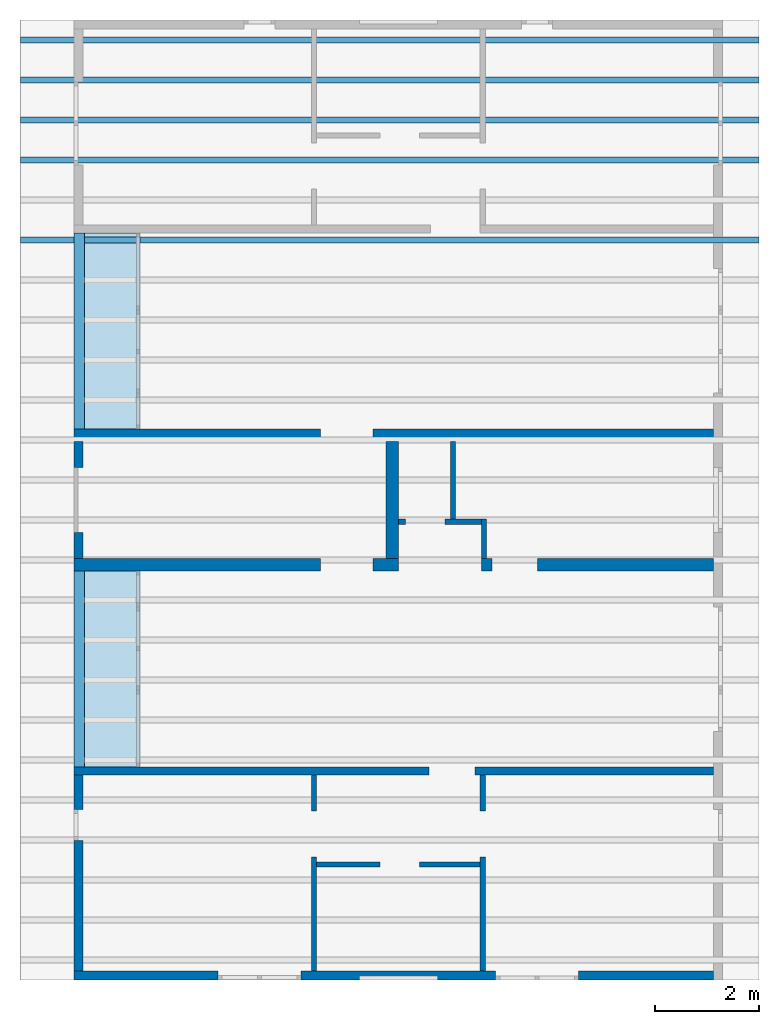
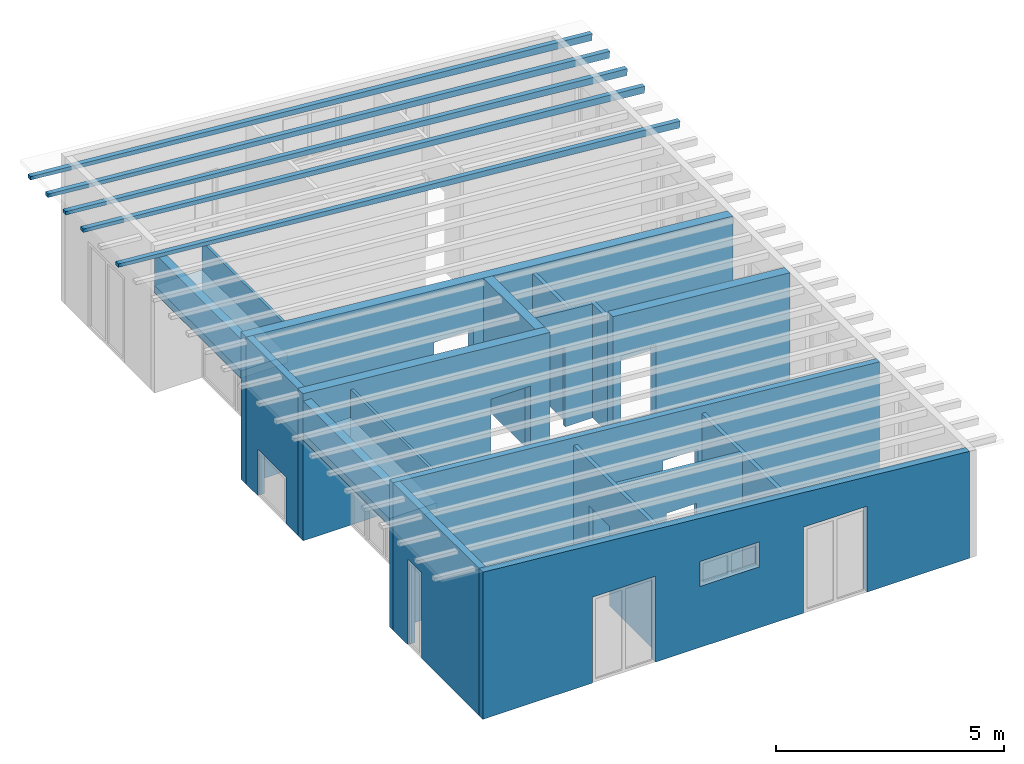
# One storey, part 1 of 13: 18 walls, 5 beams, 2 slabs, 19 openings.
"""IFC2X3 building model written with IfcOpenShell, lengths in millimetres."""

from ifc_helpers import new_model, entity, si_unit, converted_unit, frame, frame_2d, origin, origin_with_axes, place, context, project, spatial, rectangle, extrude, clip, halfspace, faceted_brep, material, layer, layer_set, layer_usage, element, save


model = new_model("IFC2X3")

# Units and contexts
model_context = context("Model", 3, precision=1e-05, world=origin())
plan_context = context("Plan", 3, precision=1e-05, world=origin())
ifc_project = project(units=[si_unit("LENGTHUNIT", "METRE", prefix="MILLI"), converted_unit("PLANEANGLEUNIT", "DEGREE", entity("IfcPlaneAngleMeasure", 0.0174532925199433), si_unit("PLANEANGLEUNIT", "RADIAN"), dimensions=[0, 0, 0, 0, 0, 0, 0]), si_unit("AREAUNIT", "SQUARE_METRE"), si_unit("VOLUMEUNIT", "CUBIC_METRE")], contexts=[model_context, plan_context])

# Building, storey
building_placement = place(None, origin())
building = spatial("IfcBuilding", under=ifc_project, at=building_placement, CompositionType="ELEMENT")
storey_placement = place(building_placement, frame((0.0, 0.0, 4770.0), z_axis=(0.0, 0.0, 1.0), x_axis=(1.0, 0.0, 0.0)))
storey = spatial("IfcBuildingStorey", under=building, at=storey_placement, Name="Geschoss", CompositionType="ELEMENT", Elevation=4770.0)

# Beams
beam_1_placement = place(storey_placement, frame((0.0, 0.0, -4770.0)))
element("IfcBeam", 1, at=beam_1_placement, inside=storey, context=model_context, shape_type="Brep", body=[
    faceted_brep([(34385.6880708781, 9363.02083332992, 7555.99098007664), (20155.7175901036, 9363.0208333996, 8710.60829407405), (20155.7175901036, 9483.0208333996, 8710.60829407405), (34385.6880708781, 9483.02083332992, 7555.99098007664), (34370.0000371835, 9363.02083333, 7376.67593442012), (34370.0000371835, 9483.02083333, 7376.67593442012), (20155.7175901036, 9483.0208333996, 8620.26450869515), (20155.7175901036, 9363.0208333996, 8620.26450869515), (34370.0000371835, 9363.02083333, 7376.67593442012), (20155.7175901036, 9363.0208333996, 8620.26450869515), (20155.7175901036, 9363.0208333996, 8710.60829407405), (34385.6880708781, 9363.02083332992, 7555.99098007664), (20155.7175901036, 9363.0208333996, 8620.26450869515), (20155.7175901036, 9483.0208333996, 8620.26450869515), (20155.7175901036, 9483.0208333996, 8710.60829407405), (20155.7175901036, 9363.0208333996, 8710.60829407405), (20155.7175901036, 9483.0208333996, 8620.26450869515), (34370.0000371835, 9483.02083333, 7376.67593442012), (34385.6880708781, 9483.02083332992, 7555.99098007664), (20155.7175901036, 9483.0208333996, 8710.60829407405), (34370.0000371835, 9483.02083333, 7376.67593442012), (34370.0000371835, 9363.02083333, 7376.67593442012), (34385.6880708781, 9363.02083332992, 7555.99098007664), (34385.6880708781, 9483.02083332992, 7555.99098007664)], [[[0, 1, 2, 3]], [[4, 5, 6, 7]], [[8, 9, 10, 11]], [[12, 13, 14, 15]], [[16, 17, 18, 19]], [[20, 21, 22, 23]]], orient=[[False], [False], [False], [False], [False], [False]]),
])
beam_2_placement = place(storey_placement, frame((0.0, 0.0, -4770.0)))
element("IfcBeam", 2, at=beam_2_placement, inside=storey, context=model_context, shape_type="Brep", body=[
    faceted_brep([(34385.6880708781, 8592.18749999659, 7555.99098007664), (20155.7175901036, 8592.18750006627, 8710.60829407405), (20155.7175901036, 8712.18750006627, 8710.60829407405), (34385.6880708781, 8712.18749999659, 7555.99098007664), (34370.0000371835, 8592.18749999666, 7376.67593442012), (34370.0000371835, 8712.18749999666, 7376.67593442012), (20155.7175901036, 8712.18750006627, 8620.26450869515), (20155.7175901036, 8592.18750006627, 8620.26450869515), (34370.0000371835, 8592.18749999666, 7376.67593442012), (20155.7175901036, 8592.18750006627, 8620.26450869515), (20155.7175901036, 8592.18750006627, 8710.60829407405), (34385.6880708781, 8592.18749999659, 7555.99098007664), (20155.7175901036, 8592.18750006627, 8620.26450869515), (20155.7175901036, 8712.18750006627, 8620.26450869515), (20155.7175901036, 8712.18750006627, 8710.60829407405), (20155.7175901036, 8592.18750006627, 8710.60829407405), (20155.7175901036, 8712.18750006627, 8620.26450869515), (34370.0000371835, 8712.18749999666, 7376.67593442012), (34385.6880708781, 8712.18749999659, 7555.99098007664), (20155.7175901036, 8712.18750006627, 8710.60829407405), (34370.0000371835, 8712.18749999666, 7376.67593442012), (34370.0000371835, 8592.18749999666, 7376.67593442012), (34385.6880708781, 8592.18749999659, 7555.99098007664), (34385.6880708781, 8712.18749999659, 7555.99098007664)], [[[0, 1, 2, 3]], [[4, 5, 6, 7]], [[8, 9, 10, 11]], [[12, 13, 14, 15]], [[16, 17, 18, 19]], [[20, 21, 22, 23]]], orient=[[False], [False], [False], [False], [False], [False]]),
])
beam_3_placement = place(storey_placement, frame((0.0, 0.0, -4770.0)))
element("IfcBeam", 3, at=beam_3_placement, inside=storey, context=model_context, shape_type="Brep", body=[
    faceted_brep([(34385.6880708781, 7821.35416666325, 7555.99098007664), (20155.7175901036, 7821.35416673293, 8710.60829407405), (20155.7175901036, 7941.35416673293, 8710.60829407405), (34385.6880708781, 7941.35416666325, 7555.99098007664), (34370.0000371835, 7821.35416666333, 7376.67593442012), (34370.0000371835, 7941.35416666333, 7376.67593442012), (20155.7175901036, 7941.35416673293, 8620.26450869515), (20155.7175901036, 7821.35416673293, 8620.26450869515), (34370.0000371835, 7821.35416666333, 7376.67593442012), (20155.7175901036, 7821.35416673293, 8620.26450869515), (20155.7175901036, 7821.35416673293, 8710.60829407405), (34385.6880708781, 7821.35416666325, 7555.99098007664), (20155.7175901036, 7821.35416673293, 8620.26450869515), (20155.7175901036, 7941.35416673293, 8620.26450869515), (20155.7175901036, 7941.35416673293, 8710.60829407405), (20155.7175901036, 7821.35416673293, 8710.60829407405), (20155.7175901036, 7941.35416673293, 8620.26450869515), (34370.0000371835, 7941.35416666333, 7376.67593442012), (34385.6880708781, 7941.35416666325, 7555.99098007664), (20155.7175901036, 7941.35416673293, 8710.60829407405), (34370.0000371835, 7941.35416666333, 7376.67593442012), (34370.0000371835, 7821.35416666333, 7376.67593442012), (34385.6880708781, 7821.35416666325, 7555.99098007664), (34385.6880708781, 7941.35416666325, 7555.99098007664)], [[[0, 1, 2, 3]], [[4, 5, 6, 7]], [[8, 9, 10, 11]], [[12, 13, 14, 15]], [[16, 17, 18, 19]], [[20, 21, 22, 23]]], orient=[[False], [False], [False], [False], [False], [False]]),
])
beam_4_placement = place(storey_placement, frame((0.0, 0.0, -4770.0)))
element("IfcBeam", 4, at=beam_4_placement, inside=storey, context=model_context, shape_type="Brep", body=[
    faceted_brep([(34385.6880708781, 7050.52083332992, 7555.99098007664), (20155.7175901036, 7050.5208333996, 8710.60829407405), (20155.7175901036, 7170.5208333996, 8710.60829407405), (34385.6880708781, 7170.52083332992, 7555.99098007664), (34370.0000371835, 7050.52083333, 7376.67593442012), (34370.0000371835, 7170.52083333, 7376.67593442012), (20155.7175901036, 7170.5208333996, 8620.26450869515), (20155.7175901036, 7050.5208333996, 8620.26450869515), (34370.0000371835, 7050.52083333, 7376.67593442012), (20155.7175901036, 7050.5208333996, 8620.26450869515), (20155.7175901036, 7050.5208333996, 8710.60829407405), (34385.6880708781, 7050.52083332992, 7555.99098007664), (20155.7175901036, 7050.5208333996, 8620.26450869515), (20155.7175901036, 7170.5208333996, 8620.26450869515), (20155.7175901036, 7170.5208333996, 8710.60829407405), (20155.7175901036, 7050.5208333996, 8710.60829407405), (20155.7175901036, 7170.5208333996, 8620.26450869515), (34370.0000371835, 7170.52083333, 7376.67593442012), (34385.6880708781, 7170.52083332992, 7555.99098007664), (20155.7175901036, 7170.5208333996, 8710.60829407405), (34370.0000371835, 7170.52083333, 7376.67593442012), (34370.0000371835, 7050.52083333, 7376.67593442012), (34385.6880708781, 7050.52083332992, 7555.99098007664), (34385.6880708781, 7170.52083332992, 7555.99098007664)], [[[0, 1, 2, 3]], [[4, 5, 6, 7]], [[8, 9, 10, 11]], [[12, 13, 14, 15]], [[16, 17, 18, 19]], [[20, 21, 22, 23]]], orient=[[False], [False], [False], [False], [False], [False]]),
])
beam_5_placement = place(storey_placement, frame((0.0, 0.0, -4770.0)))
element("IfcBeam", 5, at=beam_5_placement, inside=storey, context=model_context, shape_type="Brep", body=[
    faceted_brep([(34385.6880708781, 5508.85416666325, 7555.99098007664), (20155.7175901036, 5508.85416673293, 8710.60829407405), (20155.7175901036, 5628.85416673293, 8710.60829407405), (34385.6880708781, 5628.85416666325, 7555.99098007664), (34370.0000371835, 5508.85416666333, 7376.67593442012), (34370.0000371835, 5628.85416666333, 7376.67593442012), (20155.7175901036, 5628.85416673293, 8620.26450869515), (20155.7175901036, 5508.85416673293, 8620.26450869515), (34370.0000371835, 5508.85416666333, 7376.67593442012), (20155.7175901036, 5508.85416673293, 8620.26450869515), (20155.7175901036, 5508.85416673293, 8710.60829407405), (34385.6880708781, 5508.85416666325, 7555.99098007664), (20155.7175901036, 5508.85416673293, 8620.26450869515), (20155.7175901036, 5628.85416673293, 8620.26450869515), (20155.7175901036, 5628.85416673293, 8710.60829407405), (20155.7175901036, 5508.85416673293, 8710.60829407405), (20155.7175901036, 5628.85416673293, 8620.26450869515), (34370.0000371835, 5628.85416666333, 7376.67593442012), (34385.6880708781, 5628.85416666325, 7555.99098007664), (20155.7175901036, 5628.85416673293, 8710.60829407405), (34370.0000371835, 5628.85416666333, 7376.67593442012), (34370.0000371835, 5508.85416666333, 7376.67593442012), (34385.6880708781, 5508.85416666325, 7555.99098007664), (34385.6880708781, 5628.85416666325, 7555.99098007664)], [[[0, 1, 2, 3]], [[4, 5, 6, 7]], [[8, 9, 10, 11]], [[12, 13, 14, 15]], [[16, 17, 18, 19]], [[20, 21, 22, 23]]], orient=[[False], [False], [False], [False], [False], [False]]),
])

# Slabs
ifc_material_1 = material(Name="B25")
ifc_layer_1 = layer(ifc_material_1, 200.0)
ifc_layer_set_1 = layer_set([ifc_layer_1])
ifc_layer_usage_1 = layer_usage(ifc_layer_set_1, "AXIS3", "POSITIVE", 0.0)
slab_1_placement = place(storey_placement, frame((22388.3517822139, 1928.4375, 2689.49769139612), z_axis=(0.0, 0.0, 1.0), x_axis=(1.0, 0.0, 0.0)))
element("IfcSlab", 6, at=slab_1_placement, inside=storey, material=ifc_layer_usage_1, PredefinedType="FLOOR", context=model_context, shape_type="SweptSolid", body=[
    extrude(rectangle(XDim=3780.0, YDim=1200.0, at=frame_2d((-600.0, 1890.0), x_axis=(0.0, 1.0))), origin_with_axes(), (0.0, 0.0, 1.0), 200.0),
])
ifc_material_2 = material(Name="B25")
ifc_layer_2 = layer(ifc_material_2, 200.0)
ifc_layer_set_2 = layer_set([ifc_layer_2])
ifc_layer_usage_2 = layer_usage(ifc_layer_set_2, "AXIS3", "POSITIVE", 0.0)
slab_2_placement = place(storey_placement, frame((22388.3517822102, -4591.5625, 2689.49769139612), z_axis=(0.0, 0.0, 1.0), x_axis=(1.0, 0.0, 0.0)))
element("IfcSlab", 7, at=slab_2_placement, inside=storey, material=ifc_layer_usage_2, PredefinedType="FLOOR", context=model_context, shape_type="SweptSolid", body=[
    extrude(rectangle(XDim=3780.0, YDim=1200.0, at=frame_2d((-600.0, 1890.0), x_axis=(0.0, 1.0))), origin_with_axes(), (0.0, 0.0, 1.0), 200.0),
])

# Wall, opening
ifc_material_3 = material(Name="GD")
ifc_layer_3 = layer(ifc_material_3, 100.0)
ifc_layer_set_3 = layer_set([ifc_layer_3])
ifc_layer_usage_3 = layer_usage(ifc_layer_set_3, "AXIS2", "POSITIVE", 0.0)
wall_1_placement = place(storey_placement, frame((25863.3517821692, -6516.58475652616, 0.0), z_axis=(0.0, 0.0, 1.0), x_axis=(1.0, 0.0, 0.0)))
wall_1 = element("IfcWallStandardCase", 8, at=wall_1_placement, inside=storey, material=ifc_layer_usage_3, context=model_context, shape_type="Clipping", body=[
    clip(extrude(rectangle(XDim=3150.0, YDim=100.0, at=frame_2d((1575.0, 50.0), x_axis=(1.0, 0.0))), origin_with_axes(), (0.0, 0.0, 1.0), 3331.59879209426), halfspace(frame((0.0, 0.0, 3331.59879209426), z_axis=(-0.0871557427476577, 9.20415288735212e-17, -0.996194698091746), x_axis=(1.0, 0.0, 0.0)), True)),
])
opening_1_placement = place(wall_1_placement, frame((1224.99999997392, 0.0, 0.0), z_axis=(0.0, 1.0, 0.0), x_axis=(0.0, 0.0, 1.0)))
element("IfcOpeningElement", 9, at=opening_1_placement, cuts=wall_1, ObjectType="Opening", context=model_context, shape_type="SweptSolid", body=[
    extrude(rectangle(XDim=2130.0, YDim=759.999109685581, at=frame_2d((1065.0, 379.999554842791), x_axis=(1.0, 0.0))), origin_with_axes(), (0.0, 0.0, 1.0), 100.0),
])

# Wall, openings
ifc_material_4 = material()
ifc_layer_4 = layer(ifc_material_4, 175.0)
ifc_layer_set_4 = layer_set([ifc_layer_4])
ifc_layer_usage_4 = layer_usage(ifc_layer_set_4, "AXIS2", "POSITIVE", 0.0)
wall_2_placement = place(storey_placement, frame((21188.3517822139, -8691.5625, 0.0), z_axis=(0.0, 0.0, 1.0), x_axis=(1.0, 0.0, 0.0)))
wall_2 = element("IfcWallStandardCase", 10, at=wall_2_placement, inside=storey, material=ifc_layer_usage_4, context=model_context, shape_type="Clipping", body=[
    clip(extrude(rectangle(XDim=12324.9999999553, YDim=175.0, at=frame_2d((6162.49999997765, 87.5), x_axis=(1.0, 0.0))), origin_with_axes(), (0.0, 0.0, 1.0), 3940.60829407405), halfspace(frame((12324.9999999553, 175.0, 2862.31051612095), z_axis=(-0.0871557427476578, 0.0, -0.996194698091746), x_axis=(1.0, 0.0, 0.0)), True)),
])
opening_2_placement = place(wall_2_placement, frame((8124.9982195274, 0.0, 0.0), z_axis=(0.0, 1.0, 0.0), x_axis=(0.0, 0.0, 1.0)))
element("IfcOpeningElement", 11, at=opening_2_placement, cuts=wall_2, ObjectType="Opening", context=model_context, shape_type="SweptSolid", body=[
    extrude(rectangle(XDim=2300.0, YDim=1600.0, at=frame_2d((1150.0, 800.0), x_axis=(1.0, 0.0))), origin_with_axes(), (0.0, 0.0, 1.0), 175.0),
])
opening_3_placement = place(wall_2_placement, frame((5499.99999998852, 0.0, 1635.0), z_axis=(0.0, 1.0, 0.0), x_axis=(0.0, 0.0, 1.0)))
element("IfcOpeningElement", 12, at=opening_3_placement, cuts=wall_2, ObjectType="Opening", context=model_context, shape_type="SweptSolid", body=[
    extrude(rectangle(XDim=665.0, YDim=1500.0, at=frame_2d((332.5, 750.0), x_axis=(1.0, 0.0))), origin_with_axes(), (0.0, 0.0, 1.0), 175.0),
])
opening_4_placement = place(wall_2_placement, frame((2775.00178047279, 0.0, 0.0), z_axis=(0.0, 1.0, 0.0), x_axis=(0.0, 0.0, 1.0)))
element("IfcOpeningElement", 13, at=opening_4_placement, cuts=wall_2, ObjectType="Opening", context=model_context, shape_type="SweptSolid", body=[
    extrude(rectangle(XDim=2300.0, YDim=1600.0, at=frame_2d((1150.0, 800.0), x_axis=(1.0, 0.0))), origin_with_axes(), (0.0, 0.0, 1.0), 175.0),
])

# Wall, opening
ifc_material_5 = material()
ifc_layer_5 = layer(ifc_material_5, 150.0)
ifc_layer_set_5 = layer_set([ifc_layer_5])
ifc_layer_usage_5 = layer_usage(ifc_layer_set_5, "AXIS2", "POSITIVE", 0.0)
wall_3_placement = place(storey_placement, frame((21188.3517822102, -4741.5625, 0.0), z_axis=(0.0, 0.0, 1.0), x_axis=(1.0, 0.0, 0.0)))
wall_3 = element("IfcWallStandardCase", 14, at=wall_3_placement, inside=storey, material=ifc_layer_usage_5, context=model_context, shape_type="Clipping", body=[
    clip(extrude(rectangle(XDim=12324.999999959, YDim=150.0, at=frame_2d((6162.49999997951, 75.0), x_axis=(1.0, 0.0))), origin_with_axes(), (0.0, 0.0, 1.0), 3940.60829407437), halfspace(frame((12324.999999959, 150.0, 2862.31051612095), z_axis=(-0.0871557427476578, 0.0, -0.996194698091746), x_axis=(1.0, 0.0, 0.0)), True)),
])
opening_5_placement = place(wall_3_placement, frame((6840.00089017957, 0.0, 0.0), z_axis=(0.0, 1.0, 0.0), x_axis=(0.0, 0.0, 1.0)))
element("IfcOpeningElement", 15, at=opening_5_placement, cuts=wall_3, ObjectType="Opening", context=model_context, shape_type="SweptSolid", body=[
    extrude(rectangle(XDim=2130.0, YDim=885.000000042997, at=frame_2d((1065.0, 442.500000021499), x_axis=(1.0, 0.0))), origin_with_axes(), (0.0, 0.0, 1.0), 150.0),
])

ifc_material_6 = material(Name="GD")
ifc_layer_6 = layer(ifc_material_6, 100.0)
ifc_layer_set_6 = layer_set([ifc_layer_6])
ifc_layer_usage_6 = layer_usage(ifc_layer_set_6, "AXIS2", "POSITIVE", 0.0)
wall_4_placement = place(storey_placement, frame((29113.3517821692, -8516.5625, 0.0), z_axis=(0.0, 0.0, 1.0), x_axis=(0.0, 1.0, 0.0)))
wall_4 = element("IfcWallStandardCase", 16, at=wall_4_placement, inside=storey, material=ifc_layer_usage_6, context=model_context, shape_type="Clipping", body=[
    clip(extrude(rectangle(XDim=3775.0, YDim=100.0, at=frame_2d((1887.5, 50.0), x_axis=(1.0, 0.0))), origin_with_axes(), (0.0, 0.0, 1.0), 3056.0095019876), halfspace(frame((0.0, 0.0, 3047.26063563501), z_axis=(0.0, 0.0871557427476712, -0.996194698091745), x_axis=(1.0, 0.0, 0.0)), True)),
])
opening_6_placement = place(wall_4_placement, frame((2199.97774346626, 0.0, 0.0), z_axis=(0.0, 1.0, 0.0), x_axis=(0.0, 0.0, 1.0)))
element("IfcOpeningElement", 17, at=opening_6_placement, cuts=wall_4, ObjectType="Opening", context=model_context, shape_type="SweptSolid", body=[
    extrude(rectangle(XDim=2130.0, YDim=885.000000000514, at=frame_2d((1065.0, 442.500000000257), x_axis=(1.0, 0.0))), origin_with_axes(), (0.0, 0.0, 1.0), 100.0),
])

ifc_material_7 = material(Name="GD")
ifc_layer_7 = layer(ifc_material_7, 100.0)
ifc_layer_set_7 = layer_set([ifc_layer_7])
ifc_layer_usage_7 = layer_usage(ifc_layer_set_7, "AXIS2", "POSITIVE", 0.0)
wall_5_placement = place(storey_placement, frame((25763.3517821692, -4741.56249999999, 0.0), z_axis=(0.0, 0.0, 1.0), x_axis=(0.0, -1.0, 0.0)))
wall_5 = element("IfcWallStandardCase", 18, at=wall_5_placement, inside=storey, material=ifc_layer_usage_7, context=model_context, shape_type="Clipping", body=[
    clip(extrude(rectangle(XDim=3775.00000000001, YDim=100.0, at=frame_2d((1887.5, 50.0), x_axis=(1.0, 0.0))), origin_with_axes(), (0.0, 0.0, 1.0), 3340.34765844686), halfspace(frame((0.0, 0.0, 3340.34765844686), z_axis=(0.0, -0.0871557427476533, -0.996194698091746), x_axis=(1.0, 0.0, 0.0)), True)),
])
opening_7_placement = place(wall_5_placement, frame((690.022256533231, 0.0, 0.0), z_axis=(0.0, 1.0, 0.0), x_axis=(0.0, 0.0, 1.0)))
element("IfcOpeningElement", 19, at=opening_7_placement, cuts=wall_5, ObjectType="Opening", context=model_context, shape_type="SweptSolid", body=[
    extrude(rectangle(XDim=2130.0, YDim=885.000000000514, at=frame_2d((1065.0, 442.500000000257), x_axis=(1.0, 0.0))), origin_with_axes(), (0.0, 0.0, 1.0), 100.0),
])

ifc_material_8 = material()
ifc_layer_8 = layer(ifc_material_8, 175.0)
ifc_layer_set_8 = layer_set([ifc_layer_8])
ifc_layer_usage_8 = layer_usage(ifc_layer_set_8, "AXIS2", "POSITIVE", 0.0)
wall_6_placement = place(storey_placement, frame((21188.3517822139, -4741.5625, 0.0), z_axis=(0.0, 0.0, 1.0), x_axis=(0.0, -1.0, 0.0)))
wall_6 = element("IfcWallStandardCase", 20, at=wall_6_placement, inside=storey, material=ifc_layer_usage_8, context=model_context, shape_type="Clipping", body=[
    clip(extrude(rectangle(XDim=3775.0, YDim=175.0, at=frame_2d((1887.5, 87.5), x_axis=(1.0, 0.0))), origin_with_axes(), (0.0, 0.0, 1.0), 3940.60829407405), halfspace(frame((0.0, 175.0, 3925.29777795701), z_axis=(0.0, -0.0871557427476597, -0.996194698091745), x_axis=(1.0, 0.0, 0.0)), True)),
])
opening_8_placement = place(wall_6_placement, frame((660.000000000001, 0.0, 0.0), z_axis=(0.0, 1.0, 0.0), x_axis=(0.0, 0.0, 1.0)))
element("IfcOpeningElement", 21, at=opening_8_placement, cuts=wall_6, ObjectType="Opening", context=model_context, shape_type="SweptSolid", body=[
    extrude(rectangle(XDim=2300.0, YDim=600.0, at=frame_2d((1150.0, 300.0), x_axis=(1.0, 0.0))), origin_with_axes(), (0.0, 0.0, 1.0), 175.0),
])

ifc_material_9 = material()
ifc_layer_9 = layer(ifc_material_9, 240.0)
ifc_layer_set_9 = layer_set([ifc_layer_9])
ifc_layer_usage_9 = layer_usage(ifc_layer_set_9, "AXIS2", "POSITIVE", 0.0)
wall_7_placement = place(storey_placement, frame((33513.3517821692, 1928.4375, 0.0), z_axis=(0.0, 0.0, 1.0), x_axis=(-1.0, 0.0, 0.0)))
wall_7 = element("IfcWallStandardCase", 22, at=wall_7_placement, inside=storey, material=ifc_layer_usage_9, context=model_context, shape_type="Clipping", body=[
    clip(extrude(rectangle(XDim=12324.9999999553, YDim=240.0, at=frame_2d((6162.49999997765, 120.0), x_axis=(1.0, 0.0))), origin_with_axes(), (0.0, 0.0, 1.0), 3940.60829407405), halfspace(frame((0.0, 0.0, 2862.31051612095), z_axis=(0.0871557427476578, 0.0, -0.996194698091746), x_axis=(1.0, 0.0, 0.0)), True)),
])
opening_9_placement = place(wall_7_placement, frame((6564.99999995902, 0.0, 0.0), z_axis=(0.0, 1.0, 0.0), x_axis=(0.0, 0.0, 1.0)))
element("IfcOpeningElement", 23, at=opening_9_placement, cuts=wall_7, ObjectType="Opening", context=model_context, shape_type="SweptSolid", body=[
    extrude(rectangle(XDim=2130.0, YDim=1010.0, at=frame_2d((1065.0, 505.0), x_axis=(1.0, 0.0))), origin_with_axes(), (0.0, 0.0, 1.0), 240.0),
])

ifc_material_10 = material()
ifc_layer_10 = layer(ifc_material_10, 240.0)
ifc_layer_set_10 = layer_set([ifc_layer_10])
ifc_layer_usage_10 = layer_usage(ifc_layer_set_10, "AXIS2", "POSITIVE", 0.0)
wall_8_placement = place(storey_placement, frame((33513.3517821655, -571.5625, 0.0), z_axis=(0.0, 0.0, 1.0), x_axis=(-1.0, 0.0, 0.0)))
wall_8 = element("IfcWallStandardCase", 24, at=wall_8_placement, inside=storey, material=ifc_layer_usage_10, context=model_context, shape_type="Clipping", body=[
    clip(extrude(rectangle(XDim=4474.9999999553, YDim=240.0, at=frame_2d((2237.49999997765, 120.0), x_axis=(1.0, 0.0))), origin_with_axes(), (0.0, 0.0, 1.0), 3253.82228539587), halfspace(frame((0.0, 0.0, 2862.31051612127), z_axis=(0.0871557427476578, 0.0, -0.996194698091746), x_axis=(1.0, 0.0, 0.0)), True)),
])
opening_10_placement = place(wall_8_placement, frame((3389.9999999553, 0.0, 0.0), z_axis=(0.0, 1.0, 0.0), x_axis=(0.0, 0.0, 1.0)))
element("IfcOpeningElement", 25, at=opening_10_placement, cuts=wall_8, ObjectType="Opening", context=model_context, shape_type="SweptSolid", body=[
    extrude(rectangle(XDim=2130.0, YDim=885.0, at=frame_2d((1065.0, 442.5), x_axis=(1.0, 0.0))), origin_with_axes(), (0.0, 0.0, 1.0), 240.0),
])

ifc_material_11 = material()
ifc_layer_11 = layer(ifc_material_11, 240.0)
ifc_layer_set_11 = layer_set([ifc_layer_11])
ifc_layer_usage_11 = layer_usage(ifc_layer_set_11, "AXIS2", "POSITIVE", 0.0)
wall_9_placement = place(storey_placement, frame((27438.3517822107, -571.5625, 0.0), z_axis=(0.0, 0.0, 1.0), x_axis=(-1.0, 0.0, 0.0)))
wall_9 = element("IfcWallStandardCase", 26, at=wall_9_placement, inside=storey, material=ifc_layer_usage_11, context=model_context, shape_type="Clipping", body=[
    clip(extrude(rectangle(XDim=6250.0000000005, YDim=240.0, at=frame_2d((3125.00000000025, 120.0), x_axis=(1.0, 0.0))), origin_with_axes(), (0.0, 0.0, 1.0), 3940.60829407437), halfspace(frame((0.0, 0.0, 3393.8041470373), z_axis=(0.0871557427476578, 0.0, -0.996194698091746), x_axis=(1.0, 0.0, 0.0)), True)),
])
opening_11_placement = place(wall_9_placement, frame((490.000000000498, 0.0, 0.0), z_axis=(0.0, 1.0, 0.0), x_axis=(0.0, 0.0, 1.0)))
element("IfcOpeningElement", 27, at=opening_11_placement, cuts=wall_9, ObjectType="Opening", context=model_context, shape_type="SweptSolid", body=[
    extrude(rectangle(XDim=2130.0, YDim=1010.0, at=frame_2d((1065.0, 505.0), x_axis=(1.0, 0.0))), origin_with_axes(), (0.0, 0.0, 1.0), 240.0),
])

# Wall
ifc_material_12 = material()
ifc_layer_12 = layer(ifc_material_12, 240.0)
ifc_layer_set_12 = layer_set([ifc_layer_12])
ifc_layer_usage_12 = layer_usage(ifc_layer_set_12, "AXIS2", "POSITIVE", 0.0)
wall_10_placement = place(storey_placement, frame((27198.3517822102, 1688.4375, 0.0), z_axis=(0.0, 0.0, 1.0), x_axis=(0.0, -1.0, 0.0)))
element("IfcWallStandardCase", 28, at=wall_10_placement, inside=storey, material=ifc_layer_usage_12, context=model_context, shape_type="Clipping", body=[
    clip(extrude(rectangle(XDim=2260.0, YDim=240.0, at=frame_2d((1130.0, 120.0), x_axis=(1.0, 0.0))), origin_with_axes(), (0.0, 0.0, 1.0), 3414.80142628357), halfspace(frame((0.0, 0.0, 3414.80142628357), z_axis=(0.0, -0.08715574274766, -0.996194698091745), x_axis=(1.0, 0.0, 0.0)), True)),
])

# Wall, openings
ifc_material_13 = material(Name="glas")
ifc_layer_13 = layer(ifc_material_13, 70.0)
ifc_layer_set_13 = layer_set([ifc_layer_13])
ifc_layer_usage_13 = layer_usage(ifc_layer_set_13, "AXIS2", "POSITIVE", 0.0)
wall_11_placement = place(storey_placement, frame((22458.3517822139, 1928.4375, 0.0), z_axis=(0.0, 0.0, 1.0), x_axis=(0.0, 1.0, 0.0)))
wall_11 = element("IfcWallStandardCase", 29, at=wall_11_placement, inside=storey, material=ifc_layer_usage_13, context=model_context, shape_type="Clipping", body=[
    clip(extrude(rectangle(XDim=3780.0, YDim=70.0, at=frame_2d((1890.0, 35.0), x_axis=(1.0, 0.0))), origin_with_axes(), (0.0, 0.0, 1.0), 3635.62189784294), halfspace(frame((0.0, 0.0, 3629.49769139612), z_axis=(0.0, 0.0871557427476649, -0.996194698091745), x_axis=(1.0, 0.0, 0.0)), True)),
])
opening_12_placement = place(wall_11_placement, frame((0.0, 0.0, 0.0), z_axis=(0.0, 1.0, 0.0), x_axis=(0.0, 0.0, 1.0)))
element("IfcOpeningElement", 30, at=opening_12_placement, cuts=wall_11, ObjectType="Opening", context=model_context, shape_type="SweptSolid", body=[
    extrude(rectangle(XDim=2300.0, YDim=689.999999999996, at=frame_2d((1150.0, 344.999999999998), x_axis=(1.0, 0.0))), origin_with_axes(), (0.0, 0.0, 1.0), 70.0),
])
opening_13_placement = place(wall_11_placement, frame((2290.0, 0.0, 0.0), z_axis=(0.0, 1.0, 0.0), x_axis=(0.0, 0.0, 1.0)))
element("IfcOpeningElement", 31, at=opening_13_placement, cuts=wall_11, ObjectType="Opening", context=model_context, shape_type="SweptSolid", body=[
    extrude(rectangle(XDim=2300.0, YDim=1490.0, at=frame_2d((1150.0, 745.0), x_axis=(1.0, 0.0))), origin_with_axes(), (0.0, 0.0, 1.0), 70.0),
])
opening_14_placement = place(wall_11_placement, frame((689.999999999996, 0.0, 0.0), z_axis=(0.0, 1.0, 0.0), x_axis=(0.0, 0.0, 1.0)))
element("IfcOpeningElement", 32, at=opening_14_placement, cuts=wall_11, ObjectType="Opening", context=model_context, shape_type="SweptSolid", body=[
    extrude(rectangle(XDim=2300.0, YDim=1600.0, at=frame_2d((1150.0, 800.0), x_axis=(1.0, 0.0))), origin_with_axes(), (0.0, 0.0, 1.0), 70.0),
])

ifc_material_14 = material(Name="glas")
ifc_layer_14 = layer(ifc_material_14, 70.0)
ifc_layer_set_14 = layer_set([ifc_layer_14])
ifc_layer_usage_14 = layer_usage(ifc_layer_set_14, "AXIS2", "POSITIVE", 0.0)
wall_12_placement = place(storey_placement, frame((22458.3517822139, -4591.5625, 0.0), z_axis=(0.0, 0.0, 1.0), x_axis=(0.0, 1.0, 0.0)))
wall_12 = element("IfcWallStandardCase", 33, at=wall_12_placement, inside=storey, material=ifc_layer_usage_14, context=model_context, shape_type="Clipping", body=[
    clip(extrude(rectangle(XDim=3780.0, YDim=70.0, at=frame_2d((1890.0, 35.0), x_axis=(1.0, 0.0))), origin_with_axes(), (0.0, 0.0, 1.0), 3635.62189784294), halfspace(frame((0.0, 0.0, 3629.49769139612), z_axis=(0.0, 0.0871557427476648, -0.996194698091745), x_axis=(1.0, 0.0, 0.0)), True)),
])
opening_15_placement = place(wall_12_placement, frame((3090.0, 0.0, 0.0), z_axis=(0.0, 1.0, 0.0), x_axis=(0.0, 0.0, 1.0)))
element("IfcOpeningElement", 34, at=opening_15_placement, cuts=wall_12, ObjectType="Opening", context=model_context, shape_type="SweptSolid", body=[
    extrude(rectangle(XDim=2300.0, YDim=689.999999999996, at=frame_2d((1150.0, 344.999999999998), x_axis=(1.0, 0.0))), origin_with_axes(), (0.0, 0.0, 1.0), 70.0),
])
opening_16_placement = place(wall_12_placement, frame((0.0, 0.0, 0.0), z_axis=(0.0, 1.0, 0.0), x_axis=(0.0, 0.0, 1.0)))
element("IfcOpeningElement", 35, at=opening_16_placement, cuts=wall_12, ObjectType="Opening", context=model_context, shape_type="SweptSolid", body=[
    extrude(rectangle(XDim=2300.0, YDim=1490.0, at=frame_2d((1150.0, 745.0), x_axis=(1.0, 0.0))), origin_with_axes(), (0.0, 0.0, 1.0), 70.0),
])
opening_17_placement = place(wall_12_placement, frame((1490.0, 0.0, 0.0), z_axis=(0.0, 1.0, 0.0), x_axis=(0.0, 0.0, 1.0)))
element("IfcOpeningElement", 36, at=opening_17_placement, cuts=wall_12, ObjectType="Opening", context=model_context, shape_type="SweptSolid", body=[
    extrude(rectangle(XDim=2300.0, YDim=1600.0, at=frame_2d((1150.0, 800.0), x_axis=(1.0, 0.0))), origin_with_axes(), (0.0, 0.0, 1.0), 70.0),
])

# Wall, opening
ifc_material_15 = material()
ifc_layer_15 = layer(ifc_material_15, 175.0)
ifc_layer_set_15 = layer_set([ifc_layer_15])
ifc_layer_usage_15 = layer_usage(ifc_layer_set_15, "AXIS2", "POSITIVE", 0.0)
wall_13_placement = place(storey_placement, frame((21188.3517822139, 1688.4375, 0.0), z_axis=(0.0, 0.0, 1.0), x_axis=(-1.64835853914244e-12, -1.0, 0.0)))
wall_13 = element("IfcWallStandardCase", 37, at=wall_13_placement, inside=storey, material=ifc_layer_usage_15, context=model_context, shape_type="Clipping", body=[
    clip(extrude(rectangle(XDim=2260.0, YDim=175.0, at=frame_2d((1130.0, 87.5), x_axis=(1.0, 0.0))), origin_with_axes(), (0.0, 0.0, 1.0), 3940.60829407437), halfspace(frame((7.44497875345265e-14, 175.0, 3925.29777795701), z_axis=(1.43522023988273e-13, -0.0871557427476597, -0.996194698091745), x_axis=(1.0, 0.0, 0.0)), True)),
])
opening_18_placement = place(wall_13_placement, frame((505.000000000001, -8.54925019665361e-13, 0.0), z_axis=(0.0, 1.0, 0.0), x_axis=(0.0, 0.0, 1.0)))
element("IfcOpeningElement", 38, at=opening_18_placement, cuts=wall_13, ObjectType="Opening", context=model_context, shape_type="SweptSolid", body=[
    extrude(rectangle(XDim=1250.0, YDim=1250.0, at=frame_2d((625.0, 625.0), x_axis=(1.0, 0.0))), origin_with_axes(), (0.0, 0.0, 1.0), 175.0),
])

ifc_material_16 = material(Name="GD")
ifc_layer_16 = layer(ifc_material_16, 100.0)
ifc_layer_set_16 = layer_set([ifc_layer_16])
ifc_layer_usage_16 = layer_usage(ifc_layer_set_16, "AXIS2", "POSITIVE", 0.0)
wall_14_placement = place(storey_placement, frame((29038.3517822102, 188.4375, 0.0), z_axis=(0.0, 0.0, 1.0), x_axis=(-1.0, 0.0, 0.0)))
wall_14 = element("IfcWallStandardCase", 39, at=wall_14_placement, inside=storey, material=ifc_layer_usage_16, context=model_context, shape_type="Clipping", body=[
    clip(extrude(rectangle(XDim=1600.0, YDim=100.0, at=frame_2d((800.0, 50.0), x_axis=(1.0, 0.0))), origin_with_axes(), (0.0, 0.0, 1.0), 3193.80414703735), halfspace(frame((0.0, 0.0, 3053.82228539587), z_axis=(0.0871557427476578, 0.0, -0.996194698091746), x_axis=(1.0, 0.0, 0.0)), True)),
])
opening_19_placement = place(wall_14_placement, frame((700.0, 0.0, 0.0), z_axis=(0.0, 1.0, 0.0), x_axis=(0.0, 0.0, 1.0)))
element("IfcOpeningElement", 40, at=opening_19_placement, cuts=wall_14, ObjectType="Opening", context=model_context, shape_type="SweptSolid", body=[
    extrude(rectangle(XDim=2130.0, YDim=760.0, at=frame_2d((1065.0, 380.0), x_axis=(1.0, 0.0))), origin_with_axes(), (0.0, 0.0, 1.0), 100.0),
])

# Walls
ifc_material_17 = material(Name="GD")
ifc_layer_17 = layer(ifc_material_17, 100.0)
ifc_layer_set_17 = layer_set([ifc_layer_17])
ifc_layer_usage_17 = layer_usage(ifc_layer_set_17, "AXIS2", "POSITIVE", 0.0)
wall_15_placement = place(storey_placement, frame((28438.3517822102, 1688.4375, 0.0), z_axis=(0.0, 0.0, 1.0), x_axis=(0.0, -1.0, 0.0)))
element("IfcWallStandardCase", 41, at=wall_15_placement, inside=storey, material=ifc_layer_usage_17, context=model_context, shape_type="Clipping", body=[
    clip(extrude(rectangle(XDim=1500.0, YDim=100.0, at=frame_2d((750.0, 50.0), x_axis=(1.0, 0.0))), origin_with_axes(), (0.0, 0.0, 1.0), 3106.31548351142), halfspace(frame((0.0, 0.0, 3106.31548351142), z_axis=(0.0, -0.0871557427476533, -0.996194698091746), x_axis=(1.0, 0.0, 0.0)), True)),
])
ifc_material_18 = material(Name="GD")
ifc_layer_18 = layer(ifc_material_18, 100.0)
ifc_layer_set_18 = layer_set([ifc_layer_18])
ifc_layer_usage_18 = layer_usage(ifc_layer_set_18, "AXIS2", "POSITIVE", 0.0)
wall_16_placement = place(storey_placement, frame((29138.3517822102, -571.5625, 0.0), z_axis=(0.0, 0.0, 1.0), x_axis=(0.0, 1.0, 0.0)))
element("IfcWallStandardCase", 42, at=wall_16_placement, inside=storey, material=ifc_layer_usage_18, context=model_context, shape_type="Clipping", body=[
    clip(extrude(rectangle(XDim=760.0, YDim=100.0, at=frame_2d((380.0, 50.0), x_axis=(1.0, 0.0))), origin_with_axes(), (0.0, 0.0, 1.0), 3053.82228539587), halfspace(frame((0.0, 0.0, 3045.07341904328), z_axis=(0.0, 0.0871557427476533, -0.996194698091746), x_axis=(1.0, 0.0, 0.0)), True)),
])
ifc_material_19 = material(Name="B25")
ifc_layer_19 = layer(ifc_material_19, 200.0)
ifc_layer_set_19 = layer_set([ifc_layer_19])
ifc_layer_usage_19 = layer_usage(ifc_layer_set_19, "AXIS2", "POSITIVE", 0.0)
wall_17_placement = place(storey_placement, frame((21188.3517822102, 5708.4375, 2689.5), z_axis=(0.0, 0.0, 1.0), x_axis=(0.0, -1.0, 0.0)))
element("IfcWallStandardCase", 43, at=wall_17_placement, inside=storey, material=ifc_layer_usage_19, context=model_context, shape_type="SweptSolid", body=[
    extrude(rectangle(XDim=3780.0, YDim=200.0, at=frame_2d((1890.0, 100.0), x_axis=(1.0, 0.0))), origin_with_axes(), (0.0, 0.0, 1.0), 1051.10829407404),
])
ifc_material_20 = material(Name="B25")
ifc_layer_20 = layer(ifc_material_20, 200.0)
ifc_layer_set_20 = layer_set([ifc_layer_20])
ifc_layer_usage_20 = layer_usage(ifc_layer_set_20, "AXIS2", "POSITIVE", 0.0)
wall_18_placement = place(storey_placement, frame((21188.3517822102, -811.5625, 2689.5), z_axis=(0.0, 0.0, 1.0), x_axis=(0.0, -1.0, 0.0)))
element("IfcWallStandardCase", 44, at=wall_18_placement, inside=storey, material=ifc_layer_usage_20, context=model_context, shape_type="SweptSolid", body=[
    extrude(rectangle(XDim=3780.0, YDim=200.0, at=frame_2d((1890.0, 100.0), x_axis=(1.0, 0.0))), origin_with_axes(), (0.0, 0.0, 1.0), 1051.10829407437),
])

save(model, "model.ifc")
